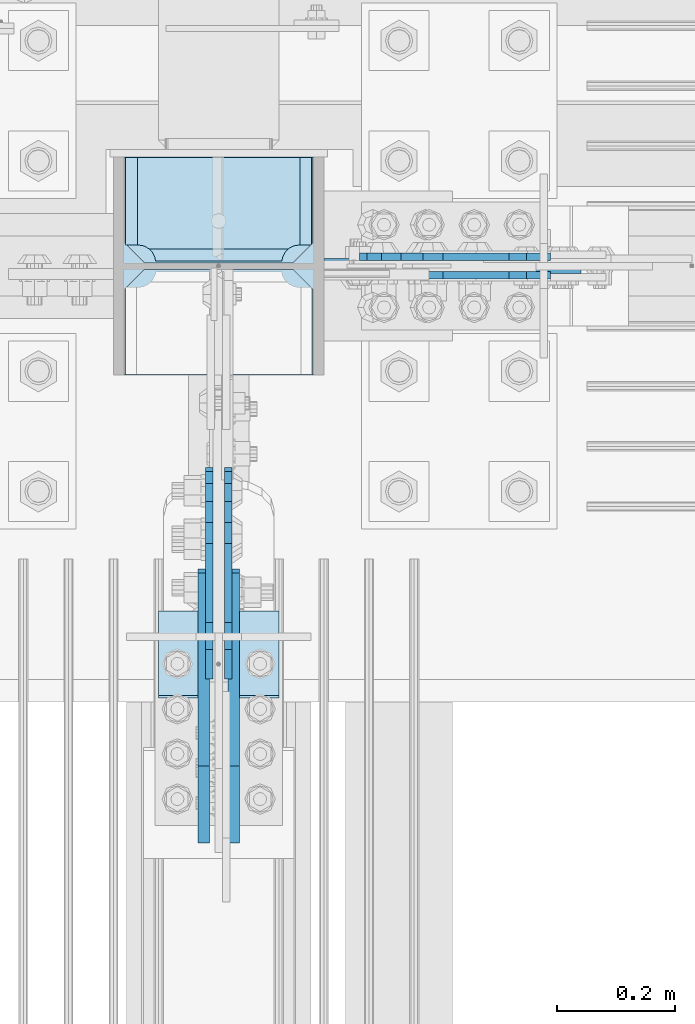
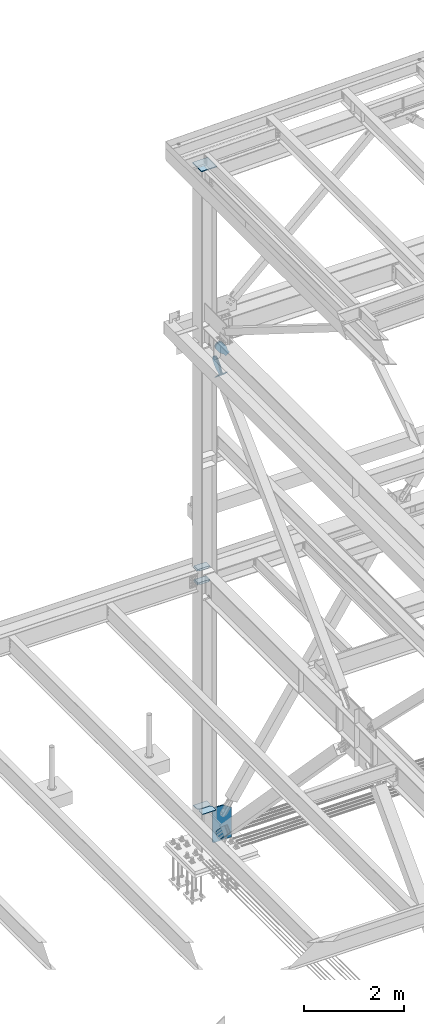
# One storey, part 3537 of 3843: 13 plates, 8 elements without a shape of their own.
"""IFC2X3 building model written with IfcOpenShell, lengths in millimetres."""

from ifc_helpers import new_model, si_unit, frame, origin_with_axes, place, context, subcontext, project, spatial, faceted_brep, material, type_object, element, aggregate, save


model = new_model("IFC2X3")

# Units and contexts
model_context = context("Model", 3, precision=1e-05, world=origin_with_axes())
body_context = subcontext(model_context, "Body", "Model", "MODEL_VIEW")
ifc_project = project(units=[si_unit("LENGTHUNIT", "METRE", prefix="MILLI"), si_unit("AREAUNIT", "SQUARE_METRE"), si_unit("VOLUMEUNIT", "CUBIC_METRE"), si_unit("MASSUNIT", "GRAM", prefix="KILO"), si_unit("TIMEUNIT", "SECOND"), si_unit("PLANEANGLEUNIT", "RADIAN"), si_unit("SOLIDANGLEUNIT", "STERADIAN"), si_unit("THERMODYNAMICTEMPERATUREUNIT", "DEGREE_CELSIUS"), si_unit("LUMINOUSINTENSITYUNIT", "LUMEN")], contexts=[model_context])

# Site, building, storey
site_placement = place(None, origin_with_axes())
site = spatial("IfcSite", under=ifc_project, at=site_placement, CompositionType="ELEMENT")
building_placement = place(site_placement, origin_with_axes())
building = spatial("IfcBuilding", under=site, at=building_placement, Name="Undefined", CompositionType="ELEMENT")
storey_placement = place(building_placement, origin_with_axes())
storey = spatial("IfcBuildingStorey", under=building, at=storey_placement, Name="Undefined", CompositionType="ELEMENT", Elevation=0.0)

# Assembly, plates
assembly_1_placement = place(storey_placement, origin_with_axes())
assembly_1 = element("IfcElementAssembly", 1, at=assembly_1_placement, inside=storey, Name="COLUMN", AssemblyPlace="NOTDEFINED", PredefinedType="RIGID_FRAME")
ifc_material_1 = material(Name="STEEL/A572-50")
plate_type_1 = type_object("IfcPlateType", PredefinedType="NOTDEFINED")
plate_1_placement = place(assembly_1_placement, frame((77171.55, 104564.65625, 30608.3225250835), z_axis=(0.0, 1.0, 0.0), x_axis=(-1.0, 0.0, 0.0)))
plate_1 = element("IfcPlate", 2, at=plate_1_placement, type_object=plate_type_1, material=ifc_material_1, Name="CB_COL", context=body_context, shape_type="Brep", body=[
    faceted_brep([(0.0, -6.34999999999854, 33.3375015258789), (0.0, -6.34999999999854, 178.59375), (0.0, 6.34999999999854, 178.59375), (0.0, 6.34999999999854, 33.3375015258789), (317.499999999985, -6.34999999999854, 178.59375), (317.499999999985, 6.34999999999854, 178.59375), (317.499999999985, -6.34999999999854, 33.3375015258789), (317.499999999985, 6.34999999999854, 33.3375015258789), (284.162498474107, -6.34999999999854, 0.0), (284.162498474107, 6.34999999999854, 0.0), (33.3375015258789, -6.34999999999854, 0.0), (33.3375015258789, 6.34999999999854, 0.0)], [[[0, 1, 2, 3]], [[1, 4, 5, 2]], [[4, 6, 7, 5]], [[6, 8, 9, 7]], [[8, 10, 11, 9]], [[10, 0, 3, 11]], [[5, 7, 9, 11, 3, 2]], [[10, 8, 6, 4, 1, 0]]]),
])
plate_2_placement = place(assembly_1_placement, frame((77171.55, 104553.54375, 30608.3225250835), z_axis=(0.0, -1.0, 0.0), x_axis=(-1.0, 0.0, 0.0)))
plate_2 = element("IfcPlate", 3, at=plate_2_placement, type_object=plate_type_1, material=ifc_material_1, Name="CB_COL", context=body_context, shape_type="Brep", body=[
    faceted_brep([(0.0, -6.34999999999854, 33.3375015258789), (0.0, -6.34999999999854, 178.59375), (0.0, 6.34999999999854, 178.59375), (0.0, 6.34999999999854, 33.3375015258789), (317.499999999985, -6.34999999999854, 178.59375), (317.499999999985, 6.34999999999854, 178.59375), (317.499999999985, -6.34999999999854, 33.3375015258789), (317.499999999985, 6.34999999999854, 33.3375015258789), (284.162498474107, -6.34999999999854, 0.0), (284.162498474107, 6.34999999999854, 0.0), (33.3375015258789, -6.34999999999854, 0.0), (33.3375015258789, 6.34999999999854, 0.0)], [[[0, 1, 2, 3]], [[1, 4, 5, 2]], [[4, 6, 7, 5]], [[6, 8, 9, 7]], [[8, 10, 11, 9]], [[10, 0, 3, 11]], [[5, 7, 9, 11, 3, 2]], [[10, 8, 6, 4, 1, 0]]]),
])
plate_type_2 = type_object("IfcPlateType", PredefinedType="NOTDEFINED")
plate_3_placement = place(assembly_1_placement, frame((77173.1375, 104742.45625, 36085.4625), z_axis=(-1.0, 0.0, 0.0), x_axis=(0.0, -1.0, 0.0)))
plate_3 = element("IfcPlate", 4, at=plate_3_placement, type_object=plate_type_2, material=ifc_material_1, Name="PLATE", context=body_context, shape_type="Brep", body=[
    faceted_brep([(160.070930155271, 7.74632228616974, 48.2144734940957), (154.461292336695, 17.4625000000015, 42.6048356755346), (154.461292336695, 17.4625000000015, 278.070152117434), (160.070930155271, 7.74632228616974, 272.460514298873), (168.479277841048, -6.81736311330314, 268.176247164767), (174.625250047655, -17.4625000000015, 267.202820796578), (174.625250047655, -17.4625000000015, 53.472166996391), (168.479277841048, -6.81736311330314, 52.4987406282016), (0.0, 17.4625000000015, 297.335542336732), (0.0, -17.4625000000015, 317.499500047692), (147.637502670288, -17.4625000000015, 317.499500047692), (147.637502670288, 17.4625000000015, 297.335542336732), (147.637502670288, 17.4625000000015, 23.3384576632816), (147.637502670288, -17.4625000000015, 3.17449995232164), (0.0, -17.4625000000015, 3.17449995232164), (0.0, 17.4625000000015, 23.3384576632816), (147.637502670288, -17.4625000000015, 296.862489700317), (147.637502670288, 17.4625000000015, 296.862489700317), (149.113760516208, -17.4625000000015, 287.541764489608), (149.113760516208, 17.4625000000015, 287.541764489608), (153.398027650313, -17.4625000000015, 279.13341680383), (153.398027650313, 17.4625000000015, 279.13341680383), (160.070930155271, -17.4625000000015, 272.460514298873), (168.479277841048, -17.4625000000015, 268.176247164767), (168.479277841048, -17.4625000000015, 52.4987406282016), (160.070930155271, -17.4625000000015, 48.2144734940957), (153.398027650313, -17.4625000000015, 41.5415709891386), (153.398027650313, 17.4625000000015, 41.5415709891386), (149.113760516208, -17.4625000000015, 33.1332233033609), (149.113760516208, 17.4625000000015, 33.1332233033609), (147.637502670288, -17.4625000000015, 23.8124980926514), (147.637502670288, 17.4625000000015, 23.8124980926514)], [[[0, 1, 2, 3, 4, 5, 6, 7]], [[8, 9, 10, 11]], [[12, 13, 14, 15]], [[9, 8, 15, 14]], [[16, 17, 11, 10]], [[16, 18, 19, 17]], [[18, 20, 21, 19]], [[21, 20, 22, 3, 2]], [[22, 23, 4, 3]], [[23, 5, 4]], [[24, 7, 6]], [[24, 25, 0, 7]], [[25, 26, 27, 1, 0]], [[26, 28, 29, 27]], [[28, 30, 31, 29]], [[31, 30, 13, 12]], [[27, 29, 31, 12, 15, 8, 11, 17, 19, 21, 2, 1]], [[13, 30, 28, 26, 25, 24, 6, 5, 23, 22, 20, 18, 16, 10, 9, 14]]]),
])
plate_4_placement = place(assembly_1_placement, frame((77173.1375, 104742.45625, 36418.8375), z_axis=(-1.0, 0.0, 0.0), x_axis=(0.0, -1.0, 0.0)))
plate_4 = element("IfcPlate", 5, at=plate_4_placement, type_object=plate_type_2, material=ifc_material_1, Name="PLATE", context=body_context, shape_type="Brep", body=[
    faceted_brep([(160.070930155271, 7.74632228616974, 48.2144734940957), (154.461292336695, 17.4625000000015, 42.6048356755346), (154.461292336695, 17.4625000000015, 278.070152117434), (160.070930155271, 7.74632228616974, 272.460514298873), (168.479277841048, -6.81736311330314, 268.176247164767), (174.625250047655, -17.4625000000015, 267.202820796578), (174.625250047655, -17.4625000000015, 53.472166996391), (168.479277841048, -6.81736311330314, 52.4987406282016), (0.0, 17.4625000000015, 297.335542336732), (0.0, -17.4625000000015, 317.499500047692), (147.637502670288, -17.4625000000015, 317.499500047692), (147.637502670288, 17.4625000000015, 297.335542336732), (147.637502670288, 17.4625000000015, 23.3384576632816), (147.637502670288, -17.4625000000015, 3.17449995232164), (0.0, -17.4625000000015, 3.17449995232164), (0.0, 17.4625000000015, 23.3384576632816), (147.637502670288, -17.4625000000015, 296.862489700317), (147.637502670288, 17.4625000000015, 296.862489700317), (149.113760516208, -17.4625000000015, 287.541764489608), (149.113760516208, 17.4625000000015, 287.541764489608), (153.398027650313, -17.4625000000015, 279.13341680383), (153.398027650313, 17.4625000000015, 279.13341680383), (160.070930155271, -17.4625000000015, 272.460514298873), (168.479277841048, -17.4625000000015, 268.176247164767), (168.479277841048, -17.4625000000015, 52.4987406282016), (160.070930155271, -17.4625000000015, 48.2144734940957), (153.398027650313, -17.4625000000015, 41.5415709891386), (153.398027650313, 17.4625000000015, 41.5415709891386), (149.113760516208, -17.4625000000015, 33.1332233033609), (149.113760516208, 17.4625000000015, 33.1332233033609), (147.637502670288, -17.4625000000015, 23.8124980926514), (147.637502670288, 17.4625000000015, 23.8124980926514)], [[[0, 1, 2, 3, 4, 5, 6, 7]], [[8, 9, 10, 11]], [[12, 13, 14, 15]], [[9, 8, 15, 14]], [[16, 17, 11, 10]], [[16, 18, 19, 17]], [[18, 20, 21, 19]], [[21, 20, 22, 3, 2]], [[22, 23, 4, 3]], [[23, 5, 4]], [[24, 7, 6]], [[24, 25, 0, 7]], [[25, 26, 27, 1, 0]], [[26, 28, 29, 27]], [[28, 30, 31, 29]], [[31, 30, 13, 12]], [[27, 29, 31, 12, 15, 8, 11, 17, 19, 21, 2, 1]], [[13, 30, 28, 26, 25, 24, 6, 5, 23, 22, 20, 18, 16, 10, 9, 14]]]),
])

# Assembly, plate
assembly_2_placement = place(storey_placement, origin_with_axes())
assembly_2 = element("IfcElementAssembly", 6, at=assembly_2_placement, inside=storey, Name="Plate", AssemblyPlace="NOTDEFINED", PredefinedType="RIGID_FRAME")
ifc_material_2 = material(Name="STEEL/A36")
plate_type_3 = type_object("IfcPlateType", PredefinedType="NOTDEFINED")
plate_5_placement = place(assembly_2_placement, frame((77114.4, 103973.879003535, 41479.0745028463), z_axis=(0.0, -0.701307718956745, 0.712858669956175), x_axis=(-1.0, 0.0, 0.0)))
plate_5 = element("IfcPlate", 7, at=plate_5_placement, type_object=plate_type_3, material=ifc_material_2, Name="Plate", context=body_context, shape_type="Brep", body=[
    faceted_brep([(0.0, -3.17499999999927, 0.0), (0.0, -3.17500000043947, 203.200000001736), (0.0, 3.1749999995518, 203.200000001743), (0.0, 3.17499999999927, 0.0), (203.200000000012, -3.17500000043947, 203.200000001736), (203.200000000012, 3.1749999995518, 203.200000001743), (203.199996948242, -3.17499999999927, 0.0), (203.199996948242, 3.17499999999927, 0.0)], [[[0, 1, 2, 3]], [[1, 4, 5, 2]], [[4, 6, 7, 5]], [[6, 0, 3, 7]], [[5, 7, 3, 2]], [[6, 4, 1, 0]]]),
])
aggregate(assembly_2, [plate_5])

assembly_3_placement = place(storey_placement, origin_with_axes())
assembly_3 = element("IfcElementAssembly", 8, at=assembly_3_placement, inside=storey, AssemblyPlace="NOTDEFINED", PredefinedType="RIGID_FRAME")
plate_type_4 = type_object("IfcPlateType", PredefinedType="NOTDEFINED")
plate_6_placement = place(assembly_3_placement, frame((76987.4, 103713.850011942, 30703.2433315634), z_axis=(0.0, -0.721558108087918, -0.692353881084366), x_axis=(0.0, 0.692353881084366, -0.721558108087918)))
plate_6 = element("IfcPlate", 9, at=plate_6_placement, type_object=plate_type_4, material=ifc_material_2, context=body_context, shape_type="Brep", body=[
    faceted_brep([(0.0, -9.52500000000146, 0.0), (7.37782102078199e-09, -9.52499999999418, 179.651701450231), (7.37782102078199e-09, 9.52499999999418, 179.651701450231), (0.0, 9.52500000000146, 0.0), (69.8500000062704, -9.52499999999418, 179.651701450392), (69.8500000062704, 9.52499999999418, 179.651701450392), (171.449999998309, -9.52499999999418, 186.663350727089), (171.449999998309, 9.52499999999418, 186.663350727089), (434.579297655291, -9.52499999999418, 186.663350728457), (434.579297655291, 9.52499999999418, 186.663350728457), (471.637405120986, -9.52499999999418, 179.292034842016), (471.637405120986, 9.52499999999418, 179.292034842016), (503.05375165752, -9.52499999999418, 158.300303204887), (503.05375165752, 9.52499999999418, 158.300303204887), (524.045483294532, -9.52499999999418, 126.883956668345), (524.045483294532, 9.52499999999418, 126.883956668345), (531.416799180792, -9.52499999999418, 89.8258522538526), (531.416799180792, 9.52499999999418, 89.8258522538526), (524.045483293885, -9.52499999999418, 52.7677447886235), (524.045483293885, 9.52499999999418, 52.7677447886235), (503.053751656611, -9.52499999999418, 21.3513982523873), (503.053751656611, 9.52499999999418, 21.3513982523873), (471.637405120178, -9.52499999999418, 0.359666615346214), (471.637405120178, 9.52499999999418, 0.359666615346214), (434.579299181831, -9.52499999999418, -7.01164927131322), (434.579299181831, 9.52499999999418, -7.01164927131322), (171.449999996272, -9.52499999999418, -7.01164927269565), (171.449999996272, 9.52499999999418, -7.01164927269565), (69.8499999979995, -9.52499999999418, -4.00177668780088e-10), (69.8499999979995, 9.52499999999418, -4.00177668780088e-10)], [[[0, 1, 2, 3]], [[1, 4, 5, 2]], [[4, 6, 7, 5]], [[6, 8, 9, 7]], [[8, 10, 11, 9]], [[10, 12, 13, 11]], [[12, 14, 15, 13]], [[14, 16, 17, 15]], [[16, 18, 19, 17]], [[18, 20, 21, 19]], [[20, 22, 23, 21]], [[22, 24, 25, 23]], [[24, 26, 27, 25]], [[26, 28, 29, 27]], [[28, 0, 3, 29]], [[5, 7, 9, 11, 13, 15, 17, 19, 21, 23, 25, 27, 29, 3, 2]], [[28, 26, 24, 22, 20, 18, 16, 14, 12, 10, 8, 6, 4, 1, 0]]]),
])
aggregate(assembly_3, [plate_6])

assembly_4_placement = place(storey_placement, origin_with_axes())
assembly_4 = element("IfcElementAssembly", 10, at=assembly_4_placement, inside=storey, AssemblyPlace="NOTDEFINED", PredefinedType="RIGID_FRAME")
plate_7_placement = place(assembly_4_placement, frame((77038.2, 103713.850011942, 30703.2433315634), z_axis=(0.0, -0.721558108087918, -0.692353881084366), x_axis=(0.0, 0.692353881084366, -0.721558108087918)))
plate_7 = element("IfcPlate", 11, at=plate_7_placement, type_object=plate_type_4, material=ifc_material_2, context=body_context, shape_type="Brep", body=[
    faceted_brep([(0.0, -9.52500000000146, 0.0), (7.37782102078199e-09, -9.52499999999418, 179.651701450231), (7.37782102078199e-09, 9.52499999999418, 179.651701450231), (0.0, 9.52500000000146, 0.0), (69.8500000062704, -9.52499999999418, 179.651701450392), (69.8500000062704, 9.52499999999418, 179.651701450392), (171.449999998309, -9.52499999999418, 186.663350727089), (171.449999998309, 9.52499999999418, 186.663350727089), (434.579297655291, -9.52499999999418, 186.663350728457), (434.579297655291, 9.52499999999418, 186.663350728457), (471.637405120986, -9.52499999999418, 179.292034842016), (471.637405120986, 9.52499999999418, 179.292034842016), (503.05375165752, -9.52499999999418, 158.300303204887), (503.05375165752, 9.52499999999418, 158.300303204887), (524.045483294532, -9.52499999999418, 126.883956668345), (524.045483294532, 9.52499999999418, 126.883956668345), (531.416799180792, -9.52499999999418, 89.8258522538526), (531.416799180792, 9.52499999999418, 89.8258522538526), (524.045483293885, -9.52499999999418, 52.7677447886235), (524.045483293885, 9.52499999999418, 52.7677447886235), (503.053751656611, -9.52499999999418, 21.3513982523873), (503.053751656611, 9.52499999999418, 21.3513982523873), (471.637405120178, -9.52499999999418, 0.359666615346214), (471.637405120178, 9.52499999999418, 0.359666615346214), (434.579299181831, -9.52499999999418, -7.01164927131322), (434.579299181831, 9.52499999999418, -7.01164927131322), (171.449999996272, -9.52499999999418, -7.01164927269565), (171.449999996272, 9.52499999999418, -7.01164927269565), (69.8499999979995, -9.52499999999418, -4.00177668780088e-10), (69.8499999979995, 9.52499999999418, -4.00177668780088e-10)], [[[0, 1, 2, 3]], [[1, 4, 5, 2]], [[4, 6, 7, 5]], [[6, 8, 9, 7]], [[8, 10, 11, 9]], [[10, 12, 13, 11]], [[12, 14, 15, 13]], [[14, 16, 17, 15]], [[16, 18, 19, 17]], [[18, 20, 21, 19]], [[20, 22, 23, 21]], [[22, 24, 25, 23]], [[24, 26, 27, 25]], [[26, 28, 29, 27]], [[28, 0, 3, 29]], [[5, 7, 9, 11, 13, 15, 17, 19, 21, 23, 25, 27, 29, 3, 2]], [[28, 26, 24, 22, 20, 18, 16, 14, 12, 10, 8, 6, 4, 1, 0]]]),
])
aggregate(assembly_4, [plate_7])

assembly_5_placement = place(storey_placement, origin_with_axes())
assembly_5 = element("IfcElementAssembly", 12, at=assembly_5_placement, inside=storey, AssemblyPlace="NOTDEFINED", PredefinedType="RIGID_FRAME")
plate_type_5 = type_object("IfcPlateType", PredefinedType="NOTDEFINED")
plate_8_placement = place(assembly_5_placement, frame((76996.925, 103939.700892202, 41509.2882911533), z_axis=(0.0, -0.701307718956745, 0.712858669956175), x_axis=(0.0, 0.712858669956106, 0.701307718956815)))
plate_8 = element("IfcPlate", 13, at=plate_8_placement, type_object=plate_type_5, material=ifc_material_2, context=body_context, shape_type="Brep", body=[
    faceted_brep([(0.0, -6.3499999046162, 0.0), (4.9622030928731e-09, -6.35000000000582, 112.184930798256), (4.9622030928731e-09, 6.35000000000582, 112.184930798256), (7.27595761418343e-12, 6.3499999046162, 0.0), (69.8500000038475, -6.35000000000582, 112.184930798168), (69.8500000038475, 6.35000000000582, 112.184930798168), (171.450000003882, -6.35000000000582, 149.754965398664), (171.450000003882, 6.35000000000582, 149.754965398664), (315.219242329083, -6.35000000000582, 149.754965398519), (315.219242329083, 6.35000000000582, 149.754965398519), (351.06232873004, -6.35000000000582, 142.625332228003), (351.06232873004, 6.35000000000582, 142.625332228003), (381.448630144558, -6.35000000000582, 122.321854736569), (381.448630144558, 6.35000000000582, 122.321854736569), (401.752107634529, -6.35000000000582, 91.9355533209819), (401.752107634529, 6.35000000000582, 91.9355533209819), (408.881740803365, -6.35000000000582, 56.0924638688084), (408.881740803365, 6.35000000000582, 56.0924638688084), (401.75210763223, -6.35000000000582, 20.2493774701215), (401.75210763223, 6.35000000000582, 20.2493774701215), (381.448630141909, -6.35000000000582, -10.1369239423584), (381.448630141909, 6.35000000000582, -10.1369239423584), (351.062328728673, -6.35000000000582, -30.4404014313986), (351.062328728673, 6.35000000000582, -30.4404014313986), (315.219240800725, -6.35000000000582, -37.5700346009617), (315.219240800725, 6.35000000000582, -37.5700346009617), (171.449999995632, -6.35000000000582, -37.5700346008307), (171.449999995632, 6.35000000000582, -37.5700346008307), (69.8499999985434, -6.35000000000582, -8.73114913702011e-11), (69.8499999985434, 6.35000000000582, -8.73114913702011e-11)], [[[0, 1, 2, 3]], [[1, 4, 5, 2]], [[4, 6, 7, 5]], [[6, 8, 9, 7]], [[8, 10, 11, 9]], [[10, 12, 13, 11]], [[12, 14, 15, 13]], [[14, 16, 17, 15]], [[16, 18, 19, 17]], [[18, 20, 21, 19]], [[20, 22, 23, 21]], [[22, 24, 25, 23]], [[24, 26, 27, 25]], [[26, 28, 29, 27]], [[28, 0, 3, 29]], [[5, 7, 9, 11, 13, 15, 17, 19, 21, 23, 25, 27, 29, 3, 2]], [[28, 26, 24, 22, 20, 18, 16, 14, 12, 10, 8, 6, 4, 1, 0]]]),
])
aggregate(assembly_5, [plate_8])

assembly_6_placement = place(storey_placement, origin_with_axes())
assembly_6 = element("IfcElementAssembly", 14, at=assembly_6_placement, inside=storey, AssemblyPlace="NOTDEFINED", PredefinedType="RIGID_FRAME")
plate_9_placement = place(assembly_6_placement, frame((77028.675, 103939.700892202, 41509.2882911533), z_axis=(0.0, -0.701307718956745, 0.712858669956175), x_axis=(0.0, 0.712858669956106, 0.701307718956815)))
plate_9 = element("IfcPlate", 15, at=plate_9_placement, type_object=plate_type_5, material=ifc_material_2, context=body_context, shape_type="Brep", body=[
    faceted_brep([(0.0, -6.3499999046162, 0.0), (4.9622030928731e-09, -6.35000000000582, 112.184930798256), (4.9622030928731e-09, 6.35000000000582, 112.184930798256), (7.27595761418343e-12, 6.3499999046162, 0.0), (69.8500000038475, -6.35000000000582, 112.184930798168), (69.8500000038475, 6.35000000000582, 112.184930798168), (171.450000003882, -6.35000000000582, 149.754965398664), (171.450000003882, 6.35000000000582, 149.754965398664), (315.219242329083, -6.35000000000582, 149.754965398519), (315.219242329083, 6.35000000000582, 149.754965398519), (351.06232873004, -6.35000000000582, 142.625332228003), (351.06232873004, 6.35000000000582, 142.625332228003), (381.448630144558, -6.35000000000582, 122.321854736569), (381.448630144558, 6.35000000000582, 122.321854736569), (401.752107634529, -6.35000000000582, 91.9355533209819), (401.752107634529, 6.35000000000582, 91.9355533209819), (408.881740803365, -6.35000000000582, 56.0924638688084), (408.881740803365, 6.35000000000582, 56.0924638688084), (401.75210763223, -6.35000000000582, 20.2493774701215), (401.75210763223, 6.35000000000582, 20.2493774701215), (381.448630141909, -6.35000000000582, -10.1369239423584), (381.448630141909, 6.35000000000582, -10.1369239423584), (351.062328728673, -6.35000000000582, -30.4404014313986), (351.062328728673, 6.35000000000582, -30.4404014313986), (315.219240800725, -6.35000000000582, -37.5700346009617), (315.219240800725, 6.35000000000582, -37.5700346009617), (171.449999995632, -6.35000000000582, -37.5700346008307), (171.449999995632, 6.35000000000582, -37.5700346008307), (69.8499999985434, -6.35000000000582, -8.73114913702011e-11), (69.8499999985434, 6.35000000000582, -8.73114913702011e-11)], [[[0, 1, 2, 3]], [[1, 4, 5, 2]], [[4, 6, 7, 5]], [[6, 8, 9, 7]], [[8, 10, 11, 9]], [[10, 12, 13, 11]], [[12, 14, 15, 13]], [[14, 16, 17, 15]], [[16, 18, 19, 17]], [[18, 20, 21, 19]], [[20, 22, 23, 21]], [[22, 24, 25, 23]], [[24, 26, 27, 25]], [[26, 28, 29, 27]], [[28, 0, 3, 29]], [[5, 7, 9, 11, 13, 15, 17, 19, 21, 23, 25, 27, 29, 3, 2]], [[28, 26, 24, 22, 20, 18, 16, 14, 12, 10, 8, 6, 4, 1, 0]]]),
])
aggregate(assembly_6, [plate_9])

assembly_7_placement = place(storey_placement, origin_with_axes())
assembly_7 = element("IfcElementAssembly", 16, at=assembly_7_placement, inside=storey, AssemblyPlace="NOTDEFINED", PredefinedType="RIGID_FRAME")
plate_10_placement = place(assembly_7_placement, frame((77532.6094716769, 104574.975, 41577.0946334989), z_axis=(-0.80910961832422, 0.0, -0.587657745235469), x_axis=(0.587657745235471, 0.0, -0.809109618324219)))
plate_10 = element("IfcPlate", 17, at=plate_10_placement, type_object=plate_type_5, material=ifc_material_2, context=body_context, shape_type="Brep", body=[
    faceted_brep([(0.0, -6.3499999046162, 0.0), (-101.600000000049, -6.35000000000582, -37.5700346004523), (-101.600000000049, 6.35000000000582, -37.5700346004523), (7.27595761418343e-12, 6.3499999046162, 0.0), (-245.369242325265, -6.35000000000582, -37.5700346003141), (-245.369242325265, 6.35000000000582, -37.5700346003141), (-281.212328726207, -6.35000000000582, -30.4404014297979), (-281.212328726207, 6.35000000000582, -30.4404014297979), (-311.59863014071, -6.35000000000582, -10.1369239383566), (-311.59863014071, 6.35000000000582, -10.1369239383566), (-331.902107630653, -6.35000000000582, 20.2493774772229), (-331.902107630653, 6.35000000000582, 20.2493774772229), (-339.031740799503, -6.35000000000582, 56.0924669294036), (-339.031740799503, 6.35000000000582, 56.0924669294036), (-331.902107628353, -6.35000000000582, 91.9355533280759), (-331.902107628353, 6.35000000000582, 91.9355533280759), (-311.598630138033, -6.35000000000582, 122.321854740563), (-311.598630138033, 6.35000000000582, 122.321854740563), (-281.212328724767, -6.35000000000582, 142.625332229603), (-281.212328724767, 6.35000000000582, 142.625332229603), (-245.369240796863, -6.35000000000582, 149.754965399145), (-245.369240796863, 6.35000000000582, 149.754965399145), (-101.599999991755, -6.35000000000582, 149.754965398992), (-101.599999991755, 6.35000000000582, 149.754965398992), (4.9622030928731e-09, -6.35000000000582, 112.184930798256), (4.9622030928731e-09, 6.35000000000582, 112.184930798256), (69.8500000038475, -6.35000000000582, 112.184930798168), (69.8500000038475, 6.35000000000582, 112.184930798168), (69.8499999985434, -6.35000000000582, -8.73114913702011e-11), (69.8499999985434, 6.35000000000582, -8.73114913702011e-11)], [[[0, 1, 2, 3]], [[1, 4, 5, 2]], [[4, 6, 7, 5]], [[6, 8, 9, 7]], [[8, 10, 11, 9]], [[10, 12, 13, 11]], [[12, 14, 15, 13]], [[14, 16, 17, 15]], [[16, 18, 19, 17]], [[18, 20, 21, 19]], [[20, 22, 23, 21]], [[22, 24, 25, 23]], [[24, 26, 27, 25]], [[26, 28, 29, 27]], [[28, 0, 3, 29]], [[5, 7, 9, 11, 13, 15, 17, 19, 21, 23, 25, 27, 29, 3, 2]], [[28, 26, 24, 22, 20, 18, 16, 14, 12, 10, 8, 6, 4, 1, 0]]]),
])
aggregate(assembly_7, [plate_10])

assembly_8_placement = place(storey_placement, origin_with_axes())
assembly_8 = element("IfcElementAssembly", 18, at=assembly_8_placement, inside=storey, AssemblyPlace="NOTDEFINED", PredefinedType="RIGID_FRAME")
plate_11_placement = place(assembly_8_placement, frame((77532.6094716769, 104543.225, 41577.0946334989), z_axis=(-0.80910961832422, 0.0, -0.587657745235469), x_axis=(0.587657745235471, 0.0, -0.809109618324219)))
plate_11 = element("IfcPlate", 19, at=plate_11_placement, type_object=plate_type_5, material=ifc_material_2, context=body_context, shape_type="Brep", body=[
    faceted_brep([(0.0, -6.3499999046162, 0.0), (-101.600000000049, -6.35000000000582, -37.5700346004523), (-101.600000000049, 6.35000000000582, -37.5700346004523), (7.27595761418343e-12, 6.3499999046162, 0.0), (-245.369242325265, -6.35000000000582, -37.5700346003141), (-245.369242325265, 6.35000000000582, -37.5700346003141), (-281.212328726207, -6.35000000000582, -30.4404014297979), (-281.212328726207, 6.35000000000582, -30.4404014297979), (-311.59863014071, -6.35000000000582, -10.1369239383566), (-311.59863014071, 6.35000000000582, -10.1369239383566), (-331.902107630653, -6.35000000000582, 20.2493774772229), (-331.902107630653, 6.35000000000582, 20.2493774772229), (-339.031740799503, -6.35000000000582, 56.0924669294036), (-339.031740799503, 6.35000000000582, 56.0924669294036), (-331.902107628353, -6.35000000000582, 91.9355533280759), (-331.902107628353, 6.35000000000582, 91.9355533280759), (-311.598630138033, -6.35000000000582, 122.321854740563), (-311.598630138033, 6.35000000000582, 122.321854740563), (-281.212328724767, -6.35000000000582, 142.625332229603), (-281.212328724767, 6.35000000000582, 142.625332229603), (-245.369240796863, -6.35000000000582, 149.754965399145), (-245.369240796863, 6.35000000000582, 149.754965399145), (-101.599999991755, -6.35000000000582, 149.754965398992), (-101.599999991755, 6.35000000000582, 149.754965398992), (4.9622030928731e-09, -6.35000000000582, 112.184930798256), (4.9622030928731e-09, 6.35000000000582, 112.184930798256), (69.8500000038475, -6.35000000000582, 112.184930798168), (69.8500000038475, 6.35000000000582, 112.184930798168), (69.8499999985434, -6.35000000000582, -8.73114913702011e-11), (69.8499999985434, 6.35000000000582, -8.73114913702011e-11)], [[[0, 1, 2, 3]], [[1, 4, 5, 2]], [[4, 6, 7, 5]], [[6, 8, 9, 7]], [[8, 10, 11, 9]], [[10, 12, 13, 11]], [[12, 14, 15, 13]], [[14, 16, 17, 15]], [[16, 18, 19, 17]], [[18, 20, 21, 19]], [[20, 22, 23, 21]], [[22, 24, 25, 23]], [[24, 26, 27, 25]], [[26, 28, 29, 27]], [[28, 0, 3, 29]], [[5, 7, 9, 11, 13, 15, 17, 19, 21, 23, 25, 27, 29, 3, 2]], [[28, 26, 24, 22, 20, 18, 16, 14, 12, 10, 8, 6, 4, 1, 0]]]),
])
aggregate(assembly_8, [plate_11])

# Plate
plate_type_6 = type_object("IfcPlateType", PredefinedType="NOTDEFINED")
plate_12_placement = place(assembly_1_placement, frame((77190.6, 104559.1, 29692.6), z_axis=(0.0, 0.0, 1.0), x_axis=(1.0, 0.0, 0.0)))
plate_12 = element("IfcPlate", 20, at=plate_12_placement, type_object=plate_type_6, material=ifc_material_1, Name="CB", context=body_context, shape_type="Brep", body=[
    faceted_brep([(0.0, -12.6999999999971, 19.0499992370605), (0.0, -12.6999999999971, 845.148481966666), (0.0, 12.6999999999971, 845.148481966666), (0.0, 12.6999999999971, 19.0499992370605), (235.998048371053, -12.6999999999971, 845.148484011748), (235.998048371053, 12.6999999999971, 845.148484011748), (434.896835871608, -12.6999999999971, 714.218014082835), (434.896835871608, 12.6999999999971, 714.218014082835), (434.896835871608, -12.6999999999971, 0.0), (434.896835871608, 12.6999999999971, 0.0), (19.0500015258731, -12.6999999999971, -6.33008312433958e-10), (19.0500015258731, 12.6999999999971, 0.0)], [[[0, 1, 2, 3]], [[1, 4, 5, 2]], [[4, 6, 7, 5]], [[6, 8, 9, 7]], [[8, 10, 11, 9]], [[10, 0, 3, 11]], [[5, 7, 9, 11, 3, 2]], [[10, 8, 6, 4, 1, 0]]]),
])

plate_type_7 = type_object("IfcPlateType", PredefinedType="NOTDEFINED")
plate_13_placement = place(assembly_1_placement, frame((77190.6, 104374.95, 46263.7743293727), z_axis=(-1.0, 0.0, 0.0), x_axis=(0.0, 1.0, 0.0)))
plate_13 = element("IfcPlate", 21, at=plate_13_placement, type_object=plate_type_7, material=ifc_material_1, Name="PLATE", context=body_context, shape_type="Brep", body=[
    faceted_brep([(0.0, -9.52500000000146, 0.0), (0.0, -9.52500000000146, 355.599999999999), (0.0, 9.52500000000146, 355.599999999999), (0.0, 9.52500000000146, 0.0), (368.299999999945, -9.52500000000146, 355.60000002454), (368.299999999945, 9.52500000000146, 355.60000002454), (368.299999999959, -9.52500000000146, -1.45519152283669e-11), (368.299999999959, 9.52500000000146, -1.45519152283669e-11)], [[[0, 1, 2, 3]], [[1, 4, 5, 2]], [[4, 6, 7, 5]], [[6, 0, 3, 7]], [[5, 7, 3, 2]], [[6, 4, 1, 0]]]),
])

aggregate(assembly_1, [plate_1, plate_2, plate_12, plate_3, plate_4, plate_13])

save(model, "model.ifc")
